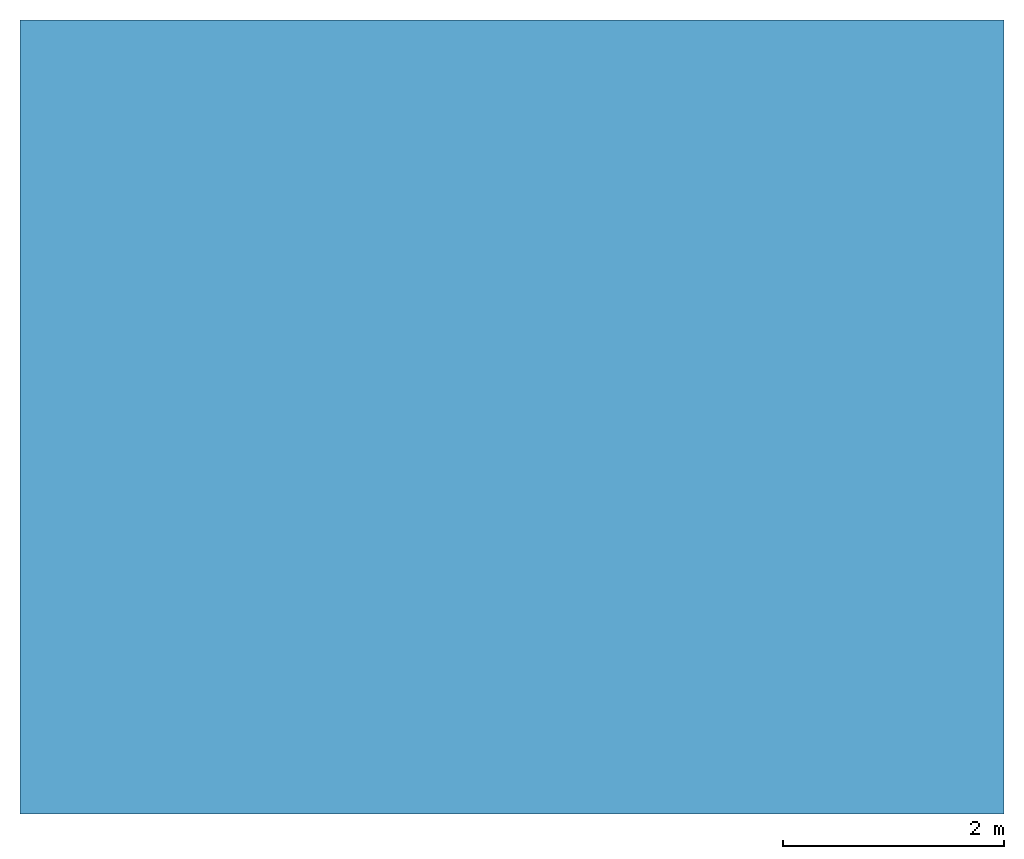
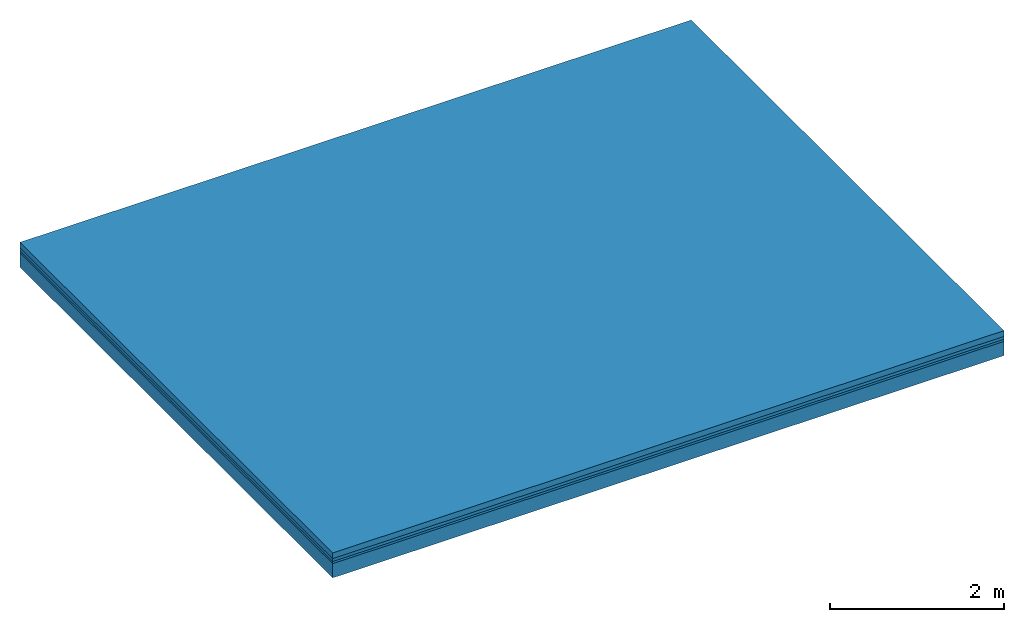
# One storey: 4 building element parts, 1 element without a shape of its own.
"""IFC2X3 building model written with IfcOpenShell, lengths in metres."""

import ifcopenshell
import ifcopenshell.guid

model = None  # the IFC model being written
_history = None  # IfcOwnerHistory: only IFC2X3 demands one
_inside = {}  # id of a spatial element -> (the spatial element, [elements in it])
_under = {}  # id of a project, library or spatial element -> (it, [spatial elements below it])
_declared = {}  # id of a project -> (the project, [libraries it declares])
_typed = {}  # id of a type object -> (the type object, [elements of that type])
_made_of = {}  # id of a material, layer set ... -> (it, [elements and type objects made of it])


def new_model(schema):
    """Start an empty IFC model of exactly this schema.

    Asked for "IFC4X3", IfcOpenShell would pick the latest addendum, in which some entities
    have other attributes; the version numbers below select the first issue.
    IFC2X3 requires an IfcOwnerHistory on every rooted entity: one is made here for all.
    """
    global model, _history
    if schema == "IFC4X3":
        model = ifcopenshell.file(schema_version=(4, 3, 0, 0))
    else:
        model = ifcopenshell.file(schema=schema)
    _inside.clear()
    _under.clear()
    _declared.clear()
    _typed.clear()
    _made_of.clear()
    _history = None
    if model.schema == "IFC2X3":
        org = make("IfcOrganization", Name="unknown")
        user = make(
            "IfcPersonAndOrganization",
            ThePerson=make("IfcPerson", FamilyName="unknown"),
            TheOrganization=org,
        )
        app = make(
            "IfcApplication",
            ApplicationDeveloper=org,
            Version="unknown",
            ApplicationFullName="unknown",
            ApplicationIdentifier="unknown",
        )
        _history = make(
            "IfcOwnerHistory",
            OwningUser=user,
            OwningApplication=app,
            ChangeAction="ADDED",
            CreationDate=0,
        )
    return model


def make(cls, **values):
    """One entity of the class cls with the attributes given. An attribute that is None is left unset."""
    return model.create_entity(
        cls, **{name: value for name, value in values.items() if value is not None}
    )


def entity(cls, *values):
    """Any entity or typed value of the class cls, its attributes in the order of the schema. None: left unset."""
    e = model.create_entity(cls)
    for i, value in enumerate(values):
        if value is not None:
            e[i] = value
    return e


def rooted(cls, **values):
    """An entity with a GlobalId (a new one), such as an element, a storey or a relation."""
    return make(cls, GlobalId=ifcopenshell.guid.new(), OwnerHistory=_history, **values)


def si_unit(unit_type, name, prefix=None):
    """IfcSIUnit, for example si_unit("LENGTHUNIT", "METRE", prefix="MILLI")."""
    return make("IfcSIUnit", UnitType=unit_type, Prefix=prefix, Name=name)


def converted_unit(unit_type, name, factor, base, dimensions=None, offset=None):
    """IfcConversionBasedUnit, such as the inch: factor (a typed value) times the base unit."""
    return make(
        "IfcConversionBasedUnit"
        if offset is None
        else "IfcConversionBasedUnitWithOffset",
        ConversionOffset=offset,
        Dimensions=None
        if dimensions is None
        else entity("IfcDimensionalExponents", *dimensions),
        UnitType=unit_type,
        Name=name,
        ConversionFactor=make(
            "IfcMeasureWithUnit", ValueComponent=factor, UnitComponent=base
        ),
    )


def derived_unit(unit_type, elements):
    """IfcDerivedUnit: a product of units, each with its exponent."""
    return make(
        "IfcDerivedUnit",
        Elements=[
            make("IfcDerivedUnitElement", Unit=unit, Exponent=power)
            for unit, power in elements
        ],
        UnitType=unit_type,
    )


def money_unit(currency):
    """IfcMonetaryUnit."""
    return make("IfcMonetaryUnit", Currency=currency)


def assignment(units):
    """IfcUnitAssignment: the units of a project."""
    return None if units is None else make("IfcUnitAssignment", Units=units)


def point(xyz):
    """IfcCartesianPoint."""
    return None if xyz is None else make("IfcCartesianPoint", Coordinates=xyz)


def direction(xyz):
    """IfcDirection."""
    return None if xyz is None else make("IfcDirection", DirectionRatios=xyz)


def frame(location, z_axis=None, x_axis=None):
    """IfcAxis2Placement3D, a coordinate frame: its origin and axes. An axis left out is left unset."""
    return make(
        "IfcAxis2Placement3D",
        Location=point(location),
        Axis=direction(z_axis),
        RefDirection=direction(x_axis),
    )


def origin_with_axes():
    """The frame at (0, 0, 0) with the z axis (0, 0, 1) and the x axis (1, 0, 0) written out."""
    return frame((0.0, 0.0, 0.0), z_axis=(0.0, 0.0, 1.0), x_axis=(1.0, 0.0, 0.0))


def place(relative_to, where):
    """IfcLocalPlacement: puts the frame where relative to a parent placement (None: the world)."""
    return make(
        "IfcLocalPlacement", PlacementRelTo=relative_to, RelativePlacement=where
    )


def context(
    kind, dimensions, precision=None, world=None, true_north=None, identifier=None
):
    """IfcGeometricRepresentationContext, for example the 3D "Model" context."""
    return make(
        "IfcGeometricRepresentationContext",
        ContextIdentifier=identifier,
        ContextType=kind,
        CoordinateSpaceDimension=dimensions,
        Precision=precision,
        WorldCoordinateSystem=world,
        TrueNorth=true_north,
    )


def subcontext(parent, identifier, kind, view, scale=None):
    """IfcGeometricRepresentationSubContext, for example "Body" below "Model"."""
    return make(
        "IfcGeometricRepresentationSubContext",
        ContextIdentifier=identifier,
        ContextType=kind,
        ParentContext=parent,
        TargetScale=scale,
        TargetView=view,
    )


def project(units=None, contexts=None):
    """IfcProject with its units and contexts."""
    return rooted(
        "IfcProject",
        Name="project",
        RepresentationContexts=contexts,
        UnitsInContext=assignment(units),
    )


def spatial(cls, under=None, at=None, **own):
    """A site, building, storey or space (cls), placed at a placement, below another one or the project."""
    s = rooted(cls, ObjectPlacement=at, **own)
    if under is not None:
        _under.setdefault(under.id(), (under, []))[1].append(s)
    return s


def polyline(points):
    """IfcPolyline through the points."""
    return make("IfcPolyline", Points=[point(p) for p in points])


def outline(outer, holes=None, kind="AREA"):
    """IfcArbitraryClosedProfileDef: a profile drawn as a closed curve; with holes, ...WithVoids."""
    if holes is None:
        return make("IfcArbitraryClosedProfileDef", ProfileType=kind, OuterCurve=outer)
    return make(
        "IfcArbitraryProfileDefWithVoids",
        ProfileType=kind,
        OuterCurve=outer,
        InnerCurves=holes,
    )


def extrude(swept, where, along, depth):
    """IfcExtrudedAreaSolid: the profile swept, set in the frame where, extruded along a direction by depth."""
    return make(
        "IfcExtrudedAreaSolid",
        SweptArea=swept,
        Position=where,
        ExtrudedDirection=direction(along),
        Depth=depth,
    )


def shape(context_of_items, identifier, shape_type, items):
    """IfcShapeRepresentation: the items that make up one representation, for example the "Body"."""
    return make(
        "IfcShapeRepresentation",
        ContextOfItems=context_of_items,
        RepresentationIdentifier=identifier,
        RepresentationType=shape_type,
        Items=items,
    )


def material(Name=None, Category=None):
    """IfcMaterial."""
    return make("IfcMaterial", Name=Name, Category=Category)


def made_of(thing, what):
    """Note that an element or type object is made of a material, layer set ...; save() writes the relation."""
    if what is not None:
        _made_of.setdefault(what.id(), (what, []))[1].append(thing)
    return thing


def type_object(cls, material=None, **own):
    """A type object (cls), such as IfcWallType, which elements share."""
    return made_of(rooted(cls, **own), material)


def element(
    cls,
    number,
    at=None,
    inside=None,
    cuts=None,
    type_object=None,
    material=None,
    context=None,
    identifier="Body",
    shape_type=None,
    held_by="IfcProductDefinitionShape",
    body=None,
    shapes=None,
    **own,
):
    """One element of the class cls, such as IfcWall. Its Tag is "e" and its number.

    at: its placement. inside: the storey or other place that contains it. cuts: it is an
    opening in that element (IfcRelVoidsElement). A single representation is given by context,
    identifier, shape_type and body (its items); several are given by shapes. held_by: the class
    of the entity that holds the representations. save() writes the other relations.
    """
    e = rooted(cls, Tag="e%d" % number, ObjectPlacement=at, **own)
    if body is not None:
        shapes = [shape(context, identifier, shape_type, body)]
    if shapes is not None:
        e.Representation = make(held_by, Representations=shapes)
    if inside is not None:
        _inside.setdefault(inside.id(), (inside, []))[1].append(e)
    if cuts is not None:
        rooted(
            "IfcRelVoidsElement", RelatingBuildingElement=cuts, RelatedOpeningElement=e
        )
    if type_object is not None:
        _typed.setdefault(type_object.id(), (type_object, []))[1].append(e)
    return made_of(e, material)


def aggregate(whole, parts):
    """IfcRelAggregates: a whole, such as a stair, and the parts it consists of."""
    return rooted("IfcRelAggregates", RelatingObject=whole, RelatedObjects=parts)


def save(model, path):
    """Write the relations noted so far, then the file.

    IfcRelAggregates (storeys below a building ...), IfcRelContainedInSpatialStructure (elements
    in a storey), IfcRelDefinesByType, IfcRelAssociatesMaterial and IfcRelDeclares: one each for
    every whole, place, type object, material and project.
    """
    for whole, parts in _under.values():
        aggregate(whole, parts)
    for where, things in _inside.values():
        rooted(
            "IfcRelContainedInSpatialStructure",
            RelatedElements=things,
            RelatingStructure=where,
        )
    for kind, things in _typed.values():
        rooted("IfcRelDefinesByType", RelatedObjects=things, RelatingType=kind)
    for what, things in _made_of.values():
        rooted("IfcRelAssociatesMaterial", RelatedObjects=things, RelatingMaterial=what)
    for by, libraries in _declared.values():
        rooted("IfcRelDeclares", RelatingContext=by, RelatedDefinitions=libraries)
    model.write(path)


model = new_model("IFC2X3")

# Units and contexts
model_context = context("Model", 3, precision=1e-05, world=origin_with_axes(), true_north=direction((0.309016994375, 0.951056516295)))
body_context = subcontext(model_context, "Body", "Model", "MODEL_VIEW")
ifc_project = project(units=[si_unit("LENGTHUNIT", "METRE"), si_unit("AREAUNIT", "SQUARE_METRE"), si_unit("VOLUMEUNIT", "CUBIC_METRE"), converted_unit("PLANEANGLEUNIT", "DEGREE", entity("IfcPlaneAngleMeasure", 0.0174532925199), si_unit("PLANEANGLEUNIT", "RADIAN"), dimensions=[0, 0, 0, 0, 0, 0, 0]), si_unit("SOLIDANGLEUNIT", "STERADIAN"), money_unit("EUR"), si_unit("TIMEUNIT", "SECOND"), si_unit("MASSUNIT", "GRAM", prefix="KILO"), si_unit("THERMODYNAMICTEMPERATUREUNIT", "DEGREE_CELSIUS"), si_unit("LUMINOUSINTENSITYUNIT", "LUMEN"), si_unit("ENERGYUNIT", "JOULE", prefix="MEGA"), derived_unit("THERMALCONDUCTANCEUNIT", [(si_unit("POWERUNIT", "WATT"), 1), (si_unit("LENGTHUNIT", "METRE"), -1), (si_unit("THERMODYNAMICTEMPERATUREUNIT", "KELVIN"), -1)]), derived_unit("SPECIFICHEATCAPACITYUNIT", [(si_unit("ENERGYUNIT", "JOULE"), 1), (si_unit("MASSUNIT", "GRAM", prefix="KILO"), -1), (si_unit("THERMODYNAMICTEMPERATUREUNIT", "KELVIN"), -1)]), derived_unit("MASSDENSITYUNIT", [(si_unit("MASSUNIT", "GRAM", prefix="KILO"), 1), (si_unit("VOLUMEUNIT", "CUBIC_METRE"), -1)])], contexts=[model_context])

# Site, building, storey
site_placement = place(None, origin_with_axes())
site = spatial("IfcSite", under=ifc_project, at=site_placement, CompositionType="ELEMENT")
building_placement = place(site_placement, origin_with_axes())
building = spatial("IfcBuilding", under=site, at=building_placement, CompositionType="ELEMENT")
storey_placement = place(building_placement, frame((0.0, 0.0, -5.88), z_axis=(0.0, 0.0, 1.0), x_axis=(1.0, 0.0, 0.0)))
storey = spatial("IfcBuildingStorey", under=building, at=storey_placement, Name="2.Untergeschoss", CompositionType="ELEMENT", Elevation=-5.88)

# Slab, building element parts
slab_type = type_object("IfcSlabType", Name="302_Decke allgemein (LOD200) 350", PredefinedType="FLOOR")
slab_placement = place(storey_placement, frame((1.43012829992, 0.404028793369, -0.15), z_axis=(0.0, 0.0, 1.0), x_axis=(1.0, 0.0, 0.0)))
slab = element("IfcSlab", 1, at=slab_placement, inside=storey, type_object=slab_type, PredefinedType="FLOOR")
ifc_material_1 = material(Name="Beton, Stahlbeton Decke")
building_element_part_1_placement = place(slab_placement, origin_with_axes())
building_element_part_1 = element("IfcBuildingElementPart", 2, at=building_element_part_1_placement, material=ifc_material_1, Name="Beton, Stahlbeton Decke", context=body_context, shape_type="SweptSolid", body=[
    extrude(outline(polyline([(0.0, 0.0), (8.91326862204, 0.0), (8.91326862204, 7.19237758183), (0.0, 7.19237758183), (0.0, 0.0)])), frame((0.0, 0.0, -0.2), z_axis=(0.0, 0.0, 1.0), x_axis=(1.0, 0.0, 0.0)), (0.0, 0.0, 1.0), 0.2),
])
ifc_material_2 = material(Name="Boden, Sand")
building_element_part_2_placement = place(slab_placement, origin_with_axes())
building_element_part_2 = element("IfcBuildingElementPart", 3, at=building_element_part_2_placement, material=ifc_material_2, Name="Boden, Sand", context=body_context, shape_type="SweptSolid", body=[
    extrude(outline(polyline([(0.0, 0.0), (8.91326862204, 0.0), (8.91326862204, 7.19237758183), (0.0, 7.19237758183), (0.0, 0.0)])), origin_with_axes(), (0.0, 0.0, 1.0), 0.03),
])
ifc_material_3 = material()
building_element_part_3_placement = place(slab_placement, origin_with_axes())
building_element_part_3 = element("IfcBuildingElementPart", 4, at=building_element_part_3_placement, material=ifc_material_3, context=body_context, shape_type="SweptSolid", body=[
    extrude(outline(polyline([(0.0, 0.0), (8.91326862204, 0.0), (8.91326862204, 7.19237758183), (0.0, 7.19237758183), (0.0, 0.0)])), frame((0.0, 0.0, 0.03), z_axis=(0.0, 0.0, 1.0), x_axis=(1.0, 0.0, 0.0)), (0.0, 0.0, 1.0), 0.04),
])
ifc_material_4 = material(Name="Estrich")
building_element_part_4_placement = place(slab_placement, origin_with_axes())
building_element_part_4 = element("IfcBuildingElementPart", 5, at=building_element_part_4_placement, material=ifc_material_4, Name="Estrich", context=body_context, shape_type="SweptSolid", body=[
    extrude(outline(polyline([(0.0, 0.0), (8.91326862204, 0.0), (8.91326862204, 7.19237758183), (0.0, 7.19237758183), (0.0, 0.0)])), frame((0.0, 0.0, 0.07), z_axis=(0.0, 0.0, 1.0), x_axis=(1.0, 0.0, 0.0)), (0.0, 0.0, 1.0), 0.08),
])
aggregate(slab, [building_element_part_1, building_element_part_2, building_element_part_3, building_element_part_4])

save(model, "model.ifc")
